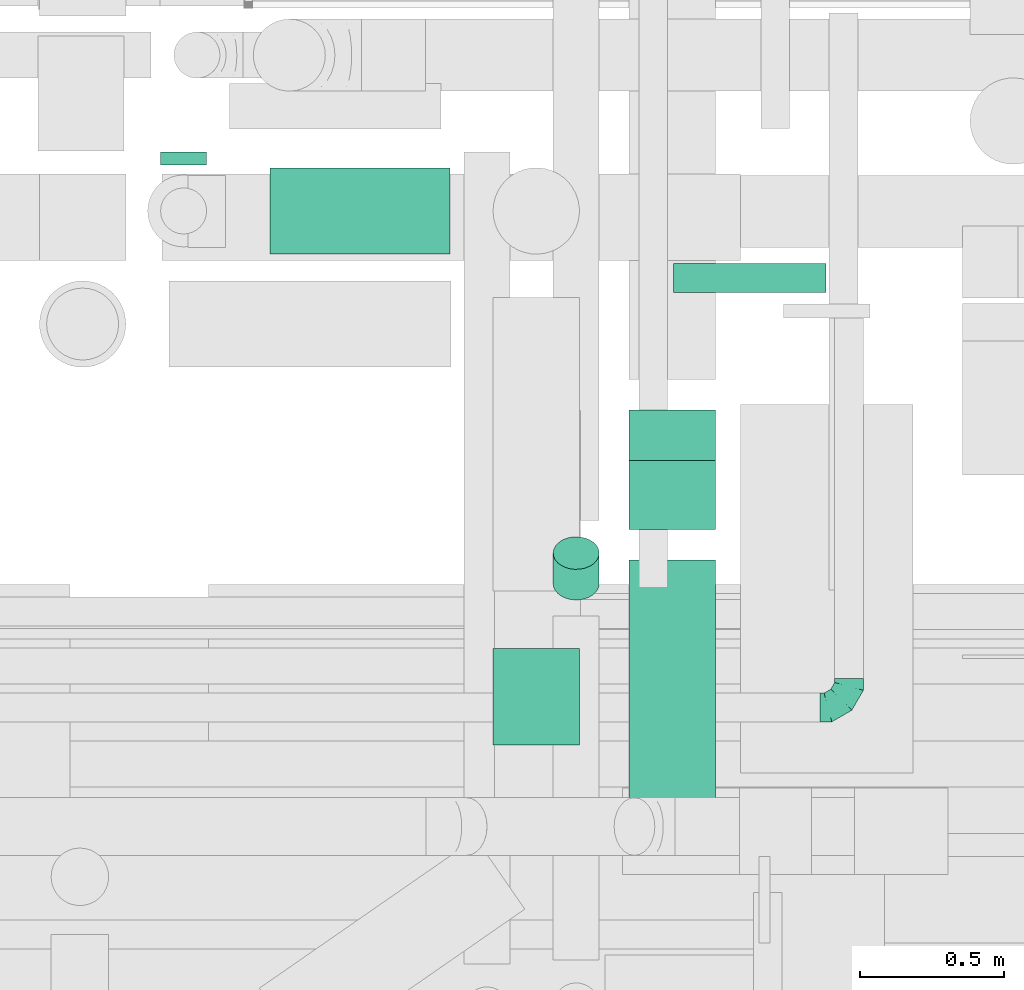
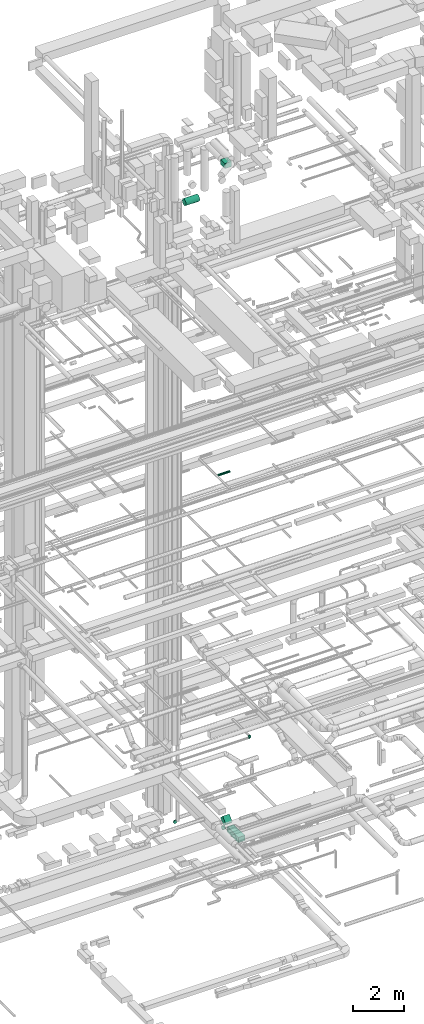
# One storey, part 141 of 337: 7 flow segments, 1 flow fitting.
"""IFC2X3 building model written with IfcOpenShell, lengths in millimetres."""

from ifc_helpers import new_model, entity, si_unit, converted_unit, derived_unit, direction, frame, frame_2d, origin, origin_2d_with_axis, place, context, subcontext, project, spatial, rectangle, circle, extrude, faceted_brep, source, transform, mapped, material, type_object, type_shapes, element, save


model = new_model("IFC2X3")

# Units and contexts
model_context = context("Model", 3, precision=0.01, world=origin(), true_north=direction((6.12303176911189e-17, 1.0)))
body_context = subcontext(model_context, "Body", "Model", "MODEL_VIEW")
ifc_project = project(units=[si_unit("LENGTHUNIT", "METRE", prefix="MILLI"), si_unit("AREAUNIT", "SQUARE_METRE"), si_unit("VOLUMEUNIT", "CUBIC_METRE"), converted_unit("PLANEANGLEUNIT", "DEGREE", entity("IfcRatioMeasure", 0.0174532925199433), si_unit("PLANEANGLEUNIT", "RADIAN"), dimensions=[0, 0, 0, 0, 0, 0, 0]), si_unit("MASSUNIT", "GRAM", prefix="KILO"), derived_unit("MASSDENSITYUNIT", [(si_unit("MASSUNIT", "GRAM", prefix="KILO"), 1), (si_unit("LENGTHUNIT", "METRE"), -3)]), derived_unit("MOMENTOFINERTIAUNIT", [(si_unit("LENGTHUNIT", "METRE"), 4)]), si_unit("TIMEUNIT", "SECOND"), si_unit("FREQUENCYUNIT", "HERTZ"), si_unit("THERMODYNAMICTEMPERATUREUNIT", "DEGREE_CELSIUS"), derived_unit("THERMALTRANSMITTANCEUNIT", [(si_unit("MASSUNIT", "GRAM", prefix="KILO"), 1), (si_unit("THERMODYNAMICTEMPERATUREUNIT", "KELVIN"), -1), (si_unit("TIMEUNIT", "SECOND"), -3)]), derived_unit("VOLUMETRICFLOWRATEUNIT", [(si_unit("LENGTHUNIT", "METRE"), 3), (si_unit("TIMEUNIT", "SECOND"), -1)]), derived_unit("MASSFLOWRATEUNIT", [(si_unit("MASSUNIT", "GRAM", prefix="KILO"), 1), (si_unit("TIMEUNIT", "SECOND"), -1)]), derived_unit("ROTATIONALFREQUENCYUNIT", [(si_unit("TIMEUNIT", "SECOND"), -1)]), si_unit("ELECTRICCURRENTUNIT", "AMPERE"), si_unit("ELECTRICVOLTAGEUNIT", "VOLT"), si_unit("POWERUNIT", "WATT"), si_unit("FORCEUNIT", "NEWTON", prefix="KILO"), si_unit("ILLUMINANCEUNIT", "LUX"), si_unit("LUMINOUSFLUXUNIT", "LUMEN"), si_unit("LUMINOUSINTENSITYUNIT", "CANDELA"), derived_unit("USERDEFINED", [(si_unit("MASSUNIT", "GRAM", prefix="KILO"), -1), (si_unit("LENGTHUNIT", "METRE"), -2), (si_unit("TIMEUNIT", "SECOND"), 3), (si_unit("LUMINOUSFLUXUNIT", "LUMEN"), 1)]), derived_unit("LINEARVELOCITYUNIT", [(si_unit("LENGTHUNIT", "METRE"), 1), (si_unit("TIMEUNIT", "SECOND"), -1)]), si_unit("PRESSUREUNIT", "PASCAL"), derived_unit("USERDEFINED", [(si_unit("LENGTHUNIT", "METRE"), -2), (si_unit("MASSUNIT", "GRAM", prefix="KILO"), 1), (si_unit("TIMEUNIT", "SECOND"), -2)]), derived_unit("LINEARFORCEUNIT", [(si_unit("MASSUNIT", "GRAM", prefix="KILO"), 1), (si_unit("LENGTHUNIT", "METRE"), 1), (si_unit("TIMEUNIT", "SECOND"), -2), (si_unit("LENGTHUNIT", "METRE"), -1)]), derived_unit("PLANARFORCEUNIT", [(si_unit("MASSUNIT", "GRAM", prefix="KILO"), 1), (si_unit("LENGTHUNIT", "METRE"), 1), (si_unit("TIMEUNIT", "SECOND"), -2), (si_unit("LENGTHUNIT", "METRE"), -2)])], contexts=[model_context])

# Site, building, storey
site_placement = place(None, origin())
site = spatial("IfcSite", under=ifc_project, at=site_placement, CompositionType="ELEMENT")
building_placement = place(site_placement, origin())
building = spatial("IfcBuilding", under=site, at=building_placement, CompositionType="ELEMENT")
storey_placement = place(building_placement, origin())
storey = spatial("IfcBuildingStorey", under=building, at=storey_placement, CompositionType="ELEMENT", Elevation=0.0)

# Flow segments
duct_segment_type_1 = type_object("IfcDuctSegmentType", PredefinedType="NOTDEFINED")
flow_segment_1_placement = place(storey_placement, frame((33038.7, 9545.01, -1125.0)))
element("IfcFlowSegment", 1, at=flow_segment_1_placement, inside=storey, type_object=duct_segment_type_1, context=body_context, shape_type="SweptSolid", body=[
    extrude(rectangle(XDim=879.743529057647, YDim=300.000000000001, at=origin_2d_with_axis()), frame((150.0, 439.87, 0.0), z_axis=(0.0, 0.0, 1.0), x_axis=(0.0, -1.0, 0.0)), (0.0, 0.0, 1.0), 250.0),
])
flow_segment_2_placement = place(storey_placement, frame((33038.7, 10530.82, -1007.84)))
element("IfcFlowSegment", 2, at=flow_segment_2_placement, inside=storey, type_object=duct_segment_type_1, context=body_context, shape_type="SweptSolid", body=[
    extrude(rectangle(XDim=250.000000000002, YDim=300.000000000001, at=frame_2d((0.0, 0.0), x_axis=(0.0, 1.0))), frame((150.0, 88.39, 88.39), z_axis=(0.0, 0.707106781186519, 0.707106781186576), x_axis=(-1.0, 0.0, 0.0)), (0.0, 0.0, 1.0), 337.868000999335),
])
duct_segment_type_2 = type_object("IfcDuctSegmentType", PredefinedType="NOTDEFINED")
flow_segment_3_placement = place(storey_placement, frame((31409.18, 11797.41, -1031.6)))
element("IfcFlowSegment", 3, at=flow_segment_3_placement, inside=storey, type_object=duct_segment_type_2, context=body_context, shape_type="SweptSolid", body=[
    extrude(circle(Radius=80.0, at=origin_2d_with_axis()), frame((81.6, 0.0, 81.6), z_axis=(0.0, 1.0, 0.0), x_axis=(-1.0, 0.0, 0.0)), (0.0, 0.0, 1.0), 44.0109700022278),
])
flow_segment_4_placement = place(storey_placement, frame((33192.17, 11352.9, 15248.4)))
element("IfcFlowSegment", 4, at=flow_segment_4_placement, inside=storey, type_object=duct_segment_type_2, context=body_context, shape_type="SweptSolid", body=[
    extrude(circle(Radius=50.0, at=origin_2d_with_axis()), frame((0.0, 51.6, 51.6), z_axis=(1.0, 0.0, 0.0), x_axis=(0.0, -1.0, 0.0)), (0.0, 0.0, 1.0), 530.000000000009),
])
flow_segment_5_placement = place(storey_placement, frame((31790.77, 11485.81, 28568.4)))
element("IfcFlowSegment", 5, at=flow_segment_5_placement, inside=storey, type_object=duct_segment_type_2, context=body_context, shape_type="SweptSolid", body=[
    extrude(circle(Radius=150.0, at=origin_2d_with_axis()), frame((0.0, 151.6, 151.6), z_axis=(1.0, 0.0, 0.0), x_axis=(0.0, 1.0, 0.0)), (0.0, 0.0, 1.0), 624.918726519772),
])
flow_segment_6_placement = place(storey_placement, frame((32772.88, 10284.54, -961.3)))
element("IfcFlowSegment", 6, at=flow_segment_6_placement, inside=storey, type_object=duct_segment_type_2, context=body_context, shape_type="SweptSolid", body=[
    extrude(circle(Radius=80.0, at=origin_2d_with_axis()), frame((81.6, 58.16, 58.16), z_axis=(0.0, 0.707106781186523, 0.707106781186572), x_axis=(-1.0, 0.0, 0.0)), (0.0, 0.0, 1.0), 150.294372515232),
])
duct_segment_type_3 = type_object("IfcDuctSegmentType", PredefinedType="NOTDEFINED")
flow_segment_7_placement = place(storey_placement, frame((32565.69, 9782.41, 31175.0)))
element("IfcFlowSegment", 7, at=flow_segment_7_placement, inside=storey, type_object=duct_segment_type_3, context=body_context, shape_type="SweptSolid", body=[
    extrude(rectangle(XDim=335.210387916247, YDim=300.000000000001, at=origin_2d_with_axis()), frame((150.0, 167.61, 0.0), z_axis=(0.0, 0.0, 1.0), x_axis=(0.0, 1.0, 0.0)), (0.0, 0.0, 1.0), 250.000000000004),
])

# Flow fitting
ifc_material = material()
duct_fitting_type = type_object("IfcDuctFittingType", PredefinedType="NOTDEFINED", material=ifc_material)
shared_shape = source(origin(), body_context, "Body", "Brep", [
    faceted_brep([(-100.0, 0.0, -50.0), (-100.0, -12.94, -48.3), (-100.0, -25.0, -43.3), (-100.0, -35.36, -35.36), (-100.0, -43.3, -25.0), (-100.0, -48.3, -12.94), (-100.0, -50.0, 0.0), (-100.0, -48.3, 12.94), (-100.0, -43.3, 25.0), (-100.0, -35.36, 35.36), (-100.0, -25.0, 43.3), (-100.0, -12.94, 48.3), (-100.0, 0.0, 50.0), (-100.0, 12.94, 48.3), (-100.0, 25.0, 43.3), (-100.0, 35.36, 35.36), (-100.0, 43.3, 25.0), (-100.0, 48.3, 12.94), (-100.0, 50.0, 0.0), (-100.0, 48.3, -12.94), (-100.0, 43.3, -25.0), (-100.0, 35.36, -35.36), (-100.0, 25.0, -43.3), (-100.0, 12.94, -48.3), (-76.67, 12.94, 48.3), (-79.9, 25.0, 43.3), (-73.21, 0.0, 50.0), (-82.68, 35.36, 35.36), (-86.15, 48.3, 12.94), (-86.6, 50.0, 0.0), (-84.81, 43.3, 25.0), (-84.81, 43.3, -25.0), (-82.68, 35.36, -35.36), (-86.15, 48.3, -12.94), (-76.67, 12.94, -48.3), (-73.21, 0.0, -50.0), (-79.9, 25.0, -43.3), (-69.74, -12.94, -48.3), (-66.51, -25.0, -43.3), (-63.73, -35.36, -35.36), (-61.6, -43.3, -25.0), (-60.26, -48.3, -12.94), (-59.81, -50.0, 0.0), (-60.26, -48.3, 12.94), (-61.6, -43.3, 25.0), (-63.73, -35.36, 35.36), (-66.51, -25.0, 43.3), (-69.74, -12.94, 48.3), (-36.27, 36.27, 48.3), (-45.1, 45.1, 43.3), (-26.79, 26.79, 50.0), (-52.68, 52.68, 35.36), (-58.49, 58.49, 25.0), (-62.15, 62.15, 12.94), (-63.4, 63.4, 0.0), (-62.15, 62.15, -12.94), (-58.49, 58.49, -25.0), (-52.68, 52.68, -35.36), (-36.27, 36.27, -48.3), (-26.79, 26.79, -50.0), (-45.1, 45.1, -43.3), (-17.32, 17.32, -48.3), (-8.49, 8.49, -43.3), (-0.91, 0.91, -35.36), (4.9, -4.9, -25.0), (8.56, -8.56, -12.94), (9.81, -9.81, 0.0), (8.56, -8.56, 12.94), (4.9, -4.9, 25.0), (-0.91, 0.91, 35.36), (-8.49, 8.49, 43.3), (-17.32, 17.32, 48.3), (-12.94, 76.67, 48.3), (-25.0, 79.9, 43.3), (0.0, 73.21, 50.0), (-35.36, 82.68, 35.36), (-43.3, 84.81, 25.0), (-48.3, 86.15, 12.94), (-50.0, 86.6, 0.0), (-48.3, 86.15, -12.94), (-43.3, 84.81, -25.0), (-35.36, 82.68, -35.36), (-12.94, 76.67, -48.3), (0.0, 73.21, -50.0), (-25.0, 79.9, -43.3), (12.94, 69.74, -48.3), (25.0, 66.51, -43.3), (35.36, 63.73, -35.36), (43.3, 61.6, -25.0), (48.3, 60.26, -12.94), (50.0, 59.81, 0.0), (48.3, 60.26, 12.94), (43.3, 61.6, 25.0), (35.36, 63.73, 35.36), (25.0, 66.51, 43.3), (12.94, 69.74, 48.3), (-12.94, 100.0, -48.3), (-25.0, 100.0, -43.3), (-35.36, 100.0, -35.36), (-43.3, 100.0, -25.0), (-48.3, 100.0, -12.94), (-50.0, 100.0, 0.0), (-48.3, 100.0, 12.94), (-43.3, 100.0, 25.0), (-35.36, 100.0, 35.36), (-25.0, 100.0, 43.3), (-12.94, 100.0, 48.3), (0.0, 100.0, 50.0), (12.94, 100.0, 48.3), (25.0, 100.0, 43.3), (35.36, 100.0, 35.36), (43.3, 100.0, 25.0), (48.3, 100.0, 12.94), (50.0, 100.0, 0.0), (48.3, 100.0, -12.94), (43.3, 100.0, -25.0), (35.36, 100.0, -35.36), (25.0, 100.0, -43.3), (12.94, 100.0, -48.3), (0.0, 100.0, -50.0)], [[[0, 1, 2, 3, 4, 5, 6, 7, 8, 9, 10, 11, 12, 13, 14, 15, 16, 17, 18, 19, 20, 21, 22, 23]], [[24, 25, 14, 13]], [[26, 24, 13, 12]], [[14, 25, 27, 15]], [[28, 29, 18, 17]], [[30, 28, 17, 16]], [[15, 27, 30, 16]], [[20, 31, 32, 21]], [[33, 31, 20, 19]], [[18, 29, 33, 19]], [[34, 35, 0, 23]], [[36, 34, 23, 22]], [[32, 36, 22, 21]], [[2, 1, 37, 38]], [[3, 2, 38, 39]], [[0, 35, 37, 1]], [[5, 4, 40, 41]], [[6, 5, 41, 42]], [[3, 39, 40, 4]], [[6, 42, 43, 7]], [[7, 43, 44, 8]], [[8, 44, 45, 9]], [[10, 46, 47, 11]], [[11, 47, 26, 12]], [[10, 9, 45, 46]], [[48, 49, 25, 24]], [[50, 48, 24, 26]], [[27, 25, 49, 51]], [[52, 53, 28, 30]], [[51, 52, 30, 27]], [[29, 28, 53, 54]], [[55, 56, 31, 33]], [[54, 55, 33, 29]], [[57, 32, 31, 56]], [[58, 59, 35, 34]], [[60, 58, 34, 36]], [[57, 60, 36, 32]], [[37, 35, 59, 61]], [[38, 37, 61, 62]], [[39, 38, 62, 63]], [[41, 40, 64, 65]], [[42, 41, 65, 66]], [[63, 64, 40, 39]], [[43, 42, 66, 67]], [[44, 43, 67, 68]], [[68, 69, 45, 44]], [[46, 45, 69, 70]], [[47, 46, 70, 71]], [[26, 47, 71, 50]], [[72, 73, 49, 48]], [[74, 72, 48, 50]], [[51, 49, 73, 75]], [[76, 77, 53, 52]], [[75, 76, 52, 51]], [[54, 53, 77, 78]], [[79, 80, 56, 55]], [[78, 79, 55, 54]], [[81, 57, 56, 80]], [[82, 83, 59, 58]], [[84, 82, 58, 60]], [[81, 84, 60, 57]], [[61, 59, 83, 85]], [[62, 61, 85, 86]], [[63, 62, 86, 87]], [[65, 64, 88, 89]], [[66, 65, 89, 90]], [[87, 88, 64, 63]], [[67, 66, 90, 91]], [[68, 67, 91, 92]], [[92, 93, 69, 68]], [[70, 69, 93, 94]], [[71, 70, 94, 95]], [[50, 71, 95, 74]], [[96, 97, 98, 99, 100, 101, 102, 103, 104, 105, 106, 107, 108, 109, 110, 111, 112, 113, 114, 115, 116, 117, 118, 119]], [[72, 74, 107, 106]], [[73, 72, 106, 105]], [[75, 73, 105, 104]], [[77, 76, 103, 102]], [[78, 77, 102, 101]], [[75, 104, 103, 76]], [[78, 101, 100, 79]], [[79, 100, 99, 80]], [[80, 99, 98, 81]], [[96, 119, 83, 82]], [[97, 96, 82, 84]], [[84, 81, 98, 97]], [[83, 119, 118, 85]], [[85, 118, 117, 86]], [[86, 117, 116, 87]], [[88, 115, 114, 89]], [[89, 114, 113, 90]], [[87, 116, 115, 88]], [[91, 90, 113, 112]], [[92, 91, 112, 111]], [[93, 92, 111, 110]], [[95, 94, 109, 108]], [[74, 95, 108, 107]], [[110, 109, 94, 93]]]),
])
type_shapes(duct_fitting_type, [shared_shape])
flow_fitting_placement = place(storey_placement, frame((33802.29, 9912.65, 3450.0)))
element("IfcFlowFitting", 8, at=flow_fitting_placement, inside=storey, type_object=duct_fitting_type, material=ifc_material, context=body_context, shape_type="MappedRepresentation", body=[
    mapped(shared_shape, transform((0.0, 0.0, 0.0), scale=1.0)),
])

save(model, "model.ifc")
